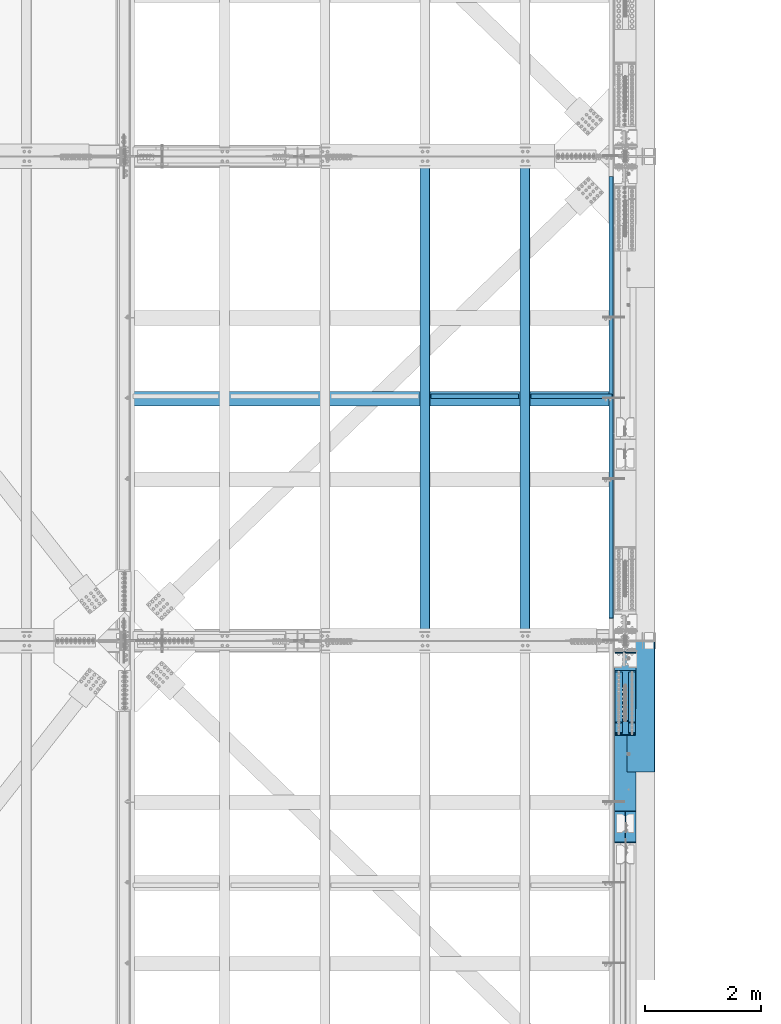
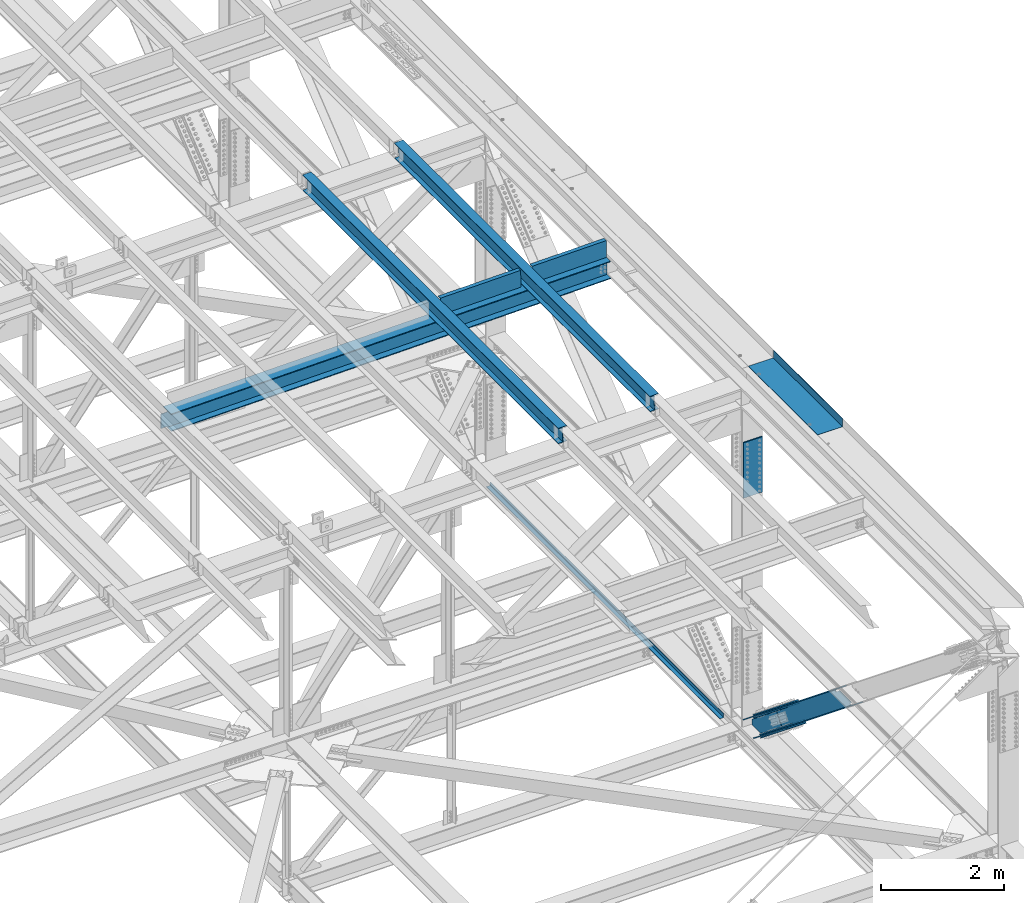
# One storey, part 1973 of 3843: 8 beams, 8 members, 10 elements without a shape of their own.
"""IFC2X3 building model written with IfcOpenShell, lengths in millimetres."""

from ifc_helpers import new_model, si_unit, frame, origin_with_axes, place, context, subcontext, project, spatial, faceted_brep, material, type_object, element, aggregate, save


model = new_model("IFC2X3")

# Units and contexts
model_context = context("Model", 3, precision=1e-05, world=origin_with_axes())
body_context = subcontext(model_context, "Body", "Model", "MODEL_VIEW")
ifc_project = project(units=[si_unit("LENGTHUNIT", "METRE", prefix="MILLI"), si_unit("AREAUNIT", "SQUARE_METRE"), si_unit("VOLUMEUNIT", "CUBIC_METRE"), si_unit("MASSUNIT", "GRAM", prefix="KILO"), si_unit("TIMEUNIT", "SECOND"), si_unit("PLANEANGLEUNIT", "RADIAN"), si_unit("SOLIDANGLEUNIT", "STERADIAN"), si_unit("THERMODYNAMICTEMPERATUREUNIT", "DEGREE_CELSIUS"), si_unit("LUMINOUSINTENSITYUNIT", "LUMEN")], contexts=[model_context])

# Site, building, storey
site_placement = place(None, origin_with_axes())
site = spatial("IfcSite", under=ifc_project, at=site_placement, CompositionType="ELEMENT")
building_placement = place(site_placement, origin_with_axes())
building = spatial("IfcBuilding", under=site, at=building_placement, Name="Undefined", CompositionType="ELEMENT")
storey_placement = place(building_placement, origin_with_axes())
storey = spatial("IfcBuildingStorey", under=building, at=storey_placement, Name="Undefined", CompositionType="ELEMENT", Elevation=0.0)

# Assembly, beam
assembly_1_placement = place(storey_placement, origin_with_axes())
assembly_1 = element("IfcElementAssembly", 1, at=assembly_1_placement, inside=storey, Name="BEAM", AssemblyPlace="NOTDEFINED", PredefinedType="RIGID_FRAME")
ifc_material_1 = material(Name="STEEL/A992")
beam_type_1 = type_object("IfcBeamType", Name="W12X26", PredefinedType="NOTDEFINED")
beam_1_placement = place(assembly_1_placement, frame((83918.3092623626, 58915.406111155, 46656.8675394248), z_axis=(-0.0211520979144407, 0.000682057999787503, 0.999776036695571), x_axis=(2.20000002012489e-08, 0.999999767294731, -0.000682210000201021)))
beam_1 = element("IfcBeam", 2, at=beam_1_placement, type_object=beam_type_1, material=ifc_material_1, Name="BEAM", ObjectType="W12X26", context=body_context, shape_type="Brep", body=[
    faceted_brep([(12.7011867508554, 82.5499999994354, -155.575000000346), (12.6947305393551, 82.5499999994572, -146.050000000338), (8343.89663442646, 82.5499999789899, -146.04999997226), (8343.90313102881, 82.5499999789899, -155.57499997229), (12.6935922641132, 3.17499999960273, -146.050000000061), (8343.89549077737, 3.17499997853884, -146.049999971998), (12.494322952225, 3.17500000000291, 146.050000000454), (8343.69626163873, 3.17499997861159, 146.050000028845), (12.4954666013145, 82.5500000004395, 146.050000000192), (8343.69740528782, 82.549999979019, 146.050000028568), (12.4889699989726, 82.5500000004395, 155.575000000223), (8343.69090868549, 82.5499999790482, 155.575000028592), (12.4865912088571, -82.550000000454, 155.575000000761), (8343.68852989539, -82.5500000218599, 155.575000029152), (12.4930878112064, -82.550000000454, 146.050000000738), (8343.69502649771, -82.5500000218599, 146.050000029121), (12.4942314602959, -3.17500000003201, 146.050000000476), (8343.69617014681, -3.17500002142333, 146.050000028852), (12.6935012020986, -3.17500000037398, -146.050000000032), (8343.89539928547, -3.17500002148154, -146.049999971976), (12.6923629268567, -82.5500000002285, -146.049999999756), (8343.89425563636, -82.5500000219035, -146.049999971714), (12.6988191383571, -82.5500000002576, -155.574999999757), (8343.90080034929, -82.5500000008251, -155.574999980301)], [[[0, 1, 2, 3]], [[1, 4, 5, 2]], [[4, 6, 7, 5]], [[6, 8, 9, 7]], [[8, 10, 11, 9]], [[10, 12, 13, 11]], [[12, 14, 15, 13]], [[14, 16, 17, 15]], [[16, 18, 19, 17]], [[18, 20, 21, 19]], [[20, 22, 23, 21]], [[22, 0, 3, 23]], [[5, 7, 9, 11, 13, 15, 17, 19, 21, 23, 3, 2]], [[22, 20, 18, 16, 14, 12, 10, 8, 6, 4, 1, 0]]]),
])
aggregate(assembly_1, [beam_1])

assembly_2_placement = place(storey_placement, origin_with_axes())
assembly_2 = element("IfcElementAssembly", 3, at=assembly_2_placement, inside=storey, Name="BEAM", AssemblyPlace="NOTDEFINED", PredefinedType="RIGID_FRAME")
beam_2_placement = place(assembly_2_placement, frame((82191.1092623841, 58915.4022524787, 46624.8375728666), z_axis=(-0.0211520975635648, 0.000657255000209259, 0.999776053316205), x_axis=(2.2000000567079e-08, 0.999999783911282, -0.000657401999942057)))
beam_2 = element("IfcBeam", 4, at=beam_2_placement, type_object=beam_type_1, material=ifc_material_1, Name="BEAM", ObjectType="W12X26", context=body_context, shape_type="Brep", body=[
    faceted_brep([(12.7011052740709, 82.550000000163, -155.575000000317), (12.6948884911471, 82.5500000001775, -146.050000000469), (8343.89668877075, 82.5499999795284, -146.050000008028), (8343.90294912967, 82.5499999795138, -155.575000008044), (12.6937864933498, 3.17499999972642, -146.050000000207), (8343.89558677295, 3.17499997907726, -146.050000007774), (12.5018021534488, 3.17500000023574, 146.050000000178), (8343.70360243306, 3.17499997960113, 146.049999992611), (12.5029041512462, 82.5500000007014, 146.049999999923), (8343.70470443086, 82.5499999800377, 146.049999992349), (12.4966437923358, 82.5500000007014, 155.574999999924), (8343.69844407195, 82.5499999800668, 155.574999992372), (12.4943516369167, -82.5500000002212, 155.575000000463), (8343.69615191653, -82.5500000208704, 155.574999992903), (12.5006119958271, -82.5500000002503, 146.050000000447), (8343.70241227544, -82.5500000208849, 146.049999992894), (12.5017139936244, -3.17499999979918, 146.050000000199), (8343.70351427323, -3.1750000204338, 146.049999992632), (12.6936983335254, -3.17500000032305, -146.050000000192), (8343.89549861313, -3.17500002095767, -146.050000007752), (12.692596335728, -82.5500000007742, -146.049999999937), (8343.89439661533, -82.5500000213942, -146.050000007497), (12.698899760122, -82.5500000007742, -155.575000000317), (8343.90065697425, -82.5500000214379, -155.575000007513)], [[[0, 1, 2, 3]], [[1, 4, 5, 2]], [[4, 6, 7, 5]], [[6, 8, 9, 7]], [[8, 10, 11, 9]], [[10, 12, 13, 11]], [[12, 14, 15, 13]], [[14, 16, 17, 15]], [[16, 18, 19, 17]], [[18, 20, 21, 19]], [[20, 22, 23, 21]], [[22, 0, 3, 23]], [[5, 7, 9, 11, 13, 15, 17, 19, 21, 23, 3, 2]], [[22, 20, 18, 16, 14, 12, 10, 8, 6, 4, 1, 0]]]),
])
aggregate(assembly_2, [beam_2])

assembly_3_placement = place(storey_placement, origin_with_axes())
assembly_3 = element("IfcElementAssembly", 5, at=assembly_3_placement, inside=storey, Name="BENT_PLATE", AssemblyPlace="NOTDEFINED", PredefinedType="RIGID_FRAME")
ifc_material_2 = material(Name="STEEL/A36")
beam_type_2 = type_object("IfcBeamType", PredefinedType="NOTDEFINED")
beam_3_placement = place(assembly_3_placement, frame((83056.8285120359, 63098.3625000037, 46453.8987739835), z_axis=(-0.999843583960508, 0.0, -0.0176863679992966), x_axis=(-0.0176863679992983, 0.0, 0.999843583960508)))
beam_3 = element("IfcBeam", 6, at=beam_3_placement, type_object=beam_type_2, material=ifc_material_2, Name="BENT_PLATE", context=body_context, shape_type="Brep", body=[
    faceted_brep([(2.38651409745216e-09, -4.76249999999709, -755.649999997448), (-2.37923813983798e-09, -4.76249999999709, 755.649999997433), (-2.37923813983798e-09, 4.76249999999709, 755.649999997433), (2.38651409745216e-09, 4.76249999999709, -755.649999997448), (327.024999945941, 4.76250000002619, 755.650000004171), (327.024999981295, 4.76250000002619, -755.650000004418), (336.549999981282, -4.76249999996799, -755.650000004447), (336.549999945928, -4.76249999996799, 755.650000004156), (327.024999958514, 71.4375000207219, 755.650000005364), (327.024999968708, 71.4375000458094, -755.650000003239), (336.549999958501, 71.4375000207219, 755.650000005349), (336.549999968687, 71.4375000458094, -755.650000003254)], [[[0, 1, 2, 3]], [[3, 2, 4, 5]], [[1, 0, 6, 7]], [[5, 4, 8, 9]], [[4, 2, 1, 7, 10, 8]], [[7, 6, 11, 10]], [[6, 0, 3, 5, 9, 11]], [[10, 11, 9, 8]]]),
])
aggregate(assembly_3, [beam_3])

assembly_4_placement = place(storey_placement, origin_with_axes())
assembly_4 = element("IfcElementAssembly", 7, at=assembly_4_placement, inside=storey, Name="BENT_PLATE", AssemblyPlace="NOTDEFINED", PredefinedType="RIGID_FRAME")
beam_4_placement = place(assembly_4_placement, frame((84728.2762852714, 63098.3625000033, 46483.296312261), z_axis=(-0.999843562078246, 0.0, -0.0176876050013672), x_axis=(-0.0176876050013679, 0.0, 0.999843562078246)))
beam_4 = element("IfcBeam", 8, at=beam_4_placement, type_object=beam_type_2, material=ifc_material_2, Name="BENT_PLATE", context=body_context, shape_type="Brep", body=[
    faceted_brep([(2.20461515709758e-09, -4.76249999999709, -698.499999997657), (-2.19733919948339e-09, -4.76249999999709, 698.499999997628), (-2.19733919948339e-09, 4.76249999999709, 698.499999997628), (2.20461515709758e-09, 4.76249999999709, -698.499999997657), (327.025000023619, 4.76250000002619, 698.499999999302), (327.025000025125, 4.76250000002619, -698.50000000326), (336.550000025134, -4.76249999996799, -698.500000003318), (336.550000023642, -4.76249999996799, 698.499999999243), (327.025000023437, 71.4374999717184, 698.499999999287), (327.025000025285, 71.4374999714419, -698.500000003274), (336.550000023461, 71.4374999717184, 698.499999999229), (336.550000025301, 71.4374999714419, -698.500000003332)], [[[0, 1, 2, 3]], [[3, 2, 4, 5]], [[1, 0, 6, 7]], [[5, 4, 8, 9]], [[4, 2, 1, 7, 10, 8]], [[7, 6, 11, 10]], [[6, 0, 3, 5, 9, 11]], [[10, 11, 9, 8]]]),
])
aggregate(assembly_4, [beam_4])

# Assembly, members
assembly_5_placement = place(storey_placement, origin_with_axes())
assembly_5 = element("IfcElementAssembly", 9, at=assembly_5_placement, inside=storey, Name="BEAM", AssemblyPlace="NOTDEFINED", PredefinedType="RIGID_FRAME")
ifc_material_3 = material(Name="STEEL/A572-50")
member_type_1 = type_object("IfcMemberType", PredefinedType="NOTDEFINED")
member_1_placement = place(assembly_5_placement, frame((85534.5, 58180.9418753998, 39957.4534431505), z_axis=(1.0, 0.0, 0.0), x_axis=(0.0, -0.777176657156862, 0.629282483127002)))
member_1 = element("IfcMember", 10, at=member_1_placement, type_object=member_type_1, material=ifc_material_3, Name="PLATE", context=body_context, shape_type="Brep", body=[
    faceted_brep([(-4.36557456851006e-11, 12.7000000000116, -63.5), (-4.36557456851006e-11, 12.7000000000116, 63.5), (1104.90000001677, 12.7000000017251, 63.5), (1104.90000001677, 12.7000000017251, -63.5), (1.45519152283669e-11, -12.700000000008, 63.5), (1104.90000001682, -12.6999999982909, 63.5), (1.45519152283669e-11, -12.700000000008, -63.5), (1104.90000001682, -12.6999999982909, -63.5)], [[[0, 1, 2, 3]], [[1, 4, 5, 2]], [[4, 6, 7, 5]], [[6, 0, 3, 7]], [[5, 7, 3, 2]], [[6, 4, 1, 0]]]),
])
member_2_placement = place(assembly_5_placement, frame((85534.5, 58366.6356795802, 40186.7890649789), z_axis=(1.0, 0.0, 0.0), x_axis=(0.0, -0.777176657156862, 0.629282483127002)))
member_2 = element("IfcMember", 11, at=member_2_placement, type_object=member_type_1, material=ifc_material_3, Name="PLATE", context=body_context, shape_type="Brep", body=[
    faceted_brep([(-4.36557456851006e-11, 12.7000000000116, -63.5), (-4.36557456851006e-11, 12.7000000000116, 63.5), (1104.90000001677, 12.7000000017251, 63.5), (1104.90000001677, 12.7000000017251, -63.5), (1.45519152283669e-11, -12.700000000008, 63.5), (1104.90000001682, -12.6999999982909, 63.5), (1.45519152283669e-11, -12.700000000008, -63.5), (1104.90000001682, -12.6999999982909, -63.5)], [[[0, 1, 2, 3]], [[1, 4, 5, 2]], [[4, 6, 7, 5]], [[6, 0, 3, 7]], [[5, 7, 3, 2]], [[6, 4, 1, 0]]]),
])
member_3_placement = place(assembly_5_placement, frame((85763.1, 58180.9418753998, 39957.4534431505), z_axis=(1.0, 0.0, 0.0), x_axis=(0.0, -0.777176657156862, 0.629282483127002)))
member_3 = element("IfcMember", 12, at=member_3_placement, type_object=member_type_1, material=ifc_material_3, Name="PLATE", context=body_context, shape_type="Brep", body=[
    faceted_brep([(-4.36557456851006e-11, 12.7000000000116, -63.5), (-4.36557456851006e-11, 12.7000000000116, 63.5), (1104.90000001677, 12.7000000017251, 63.5), (1104.90000001677, 12.7000000017251, -63.5), (1.45519152283669e-11, -12.700000000008, 63.5), (1104.90000001682, -12.6999999982909, 63.5), (1.45519152283669e-11, -12.700000000008, -63.5), (1104.90000001682, -12.6999999982909, -63.5)], [[[0, 1, 2, 3]], [[1, 4, 5, 2]], [[4, 6, 7, 5]], [[6, 0, 3, 7]], [[5, 7, 3, 2]], [[6, 4, 1, 0]]]),
])
member_4_placement = place(assembly_5_placement, frame((85763.1, 58366.6356795802, 40186.7890649789), z_axis=(1.0, 0.0, 0.0), x_axis=(0.0, -0.777176657156862, 0.629282483127002)))
member_4 = element("IfcMember", 13, at=member_4_placement, type_object=member_type_1, material=ifc_material_3, Name="PLATE", context=body_context, shape_type="Brep", body=[
    faceted_brep([(-4.36557456851006e-11, 12.7000000000116, -63.5), (-4.36557456851006e-11, 12.7000000000116, 63.5), (1104.90000001677, 12.7000000017251, 63.5), (1104.90000001677, 12.7000000017251, -63.5), (1.45519152283669e-11, -12.700000000008, 63.5), (1104.90000001682, -12.6999999982909, 63.5), (1.45519152283669e-11, -12.700000000008, -63.5), (1104.90000001682, -12.6999999982909, -63.5)], [[[0, 1, 2, 3]], [[1, 4, 5, 2]], [[4, 6, 7, 5]], [[6, 0, 3, 7]], [[5, 7, 3, 2]], [[6, 4, 1, 0]]]),
])
member_type_2 = type_object("IfcMemberType", PredefinedType="NOTDEFINED")
member_5_placement = place(assembly_5_placement, frame((85648.8, 57536.1161798013, 40916.8898443647), z_axis=(1.0, 0.0, 0.0), x_axis=(0.0, 0.777176657156857, -0.629282483127008)))
member_5 = element("IfcMember", 14, at=member_5_placement, type_object=member_type_2, material=ifc_material_3, Name="PLATE", context=body_context, shape_type="Brep", body=[
    faceted_brep([(-1.45519152283669e-11, 12.7000000000025, -177.800000000003), (-1.45519152283669e-11, 12.7000000000025, 177.800000000003), (1104.90000001682, 12.7000000017051, 177.800000000003), (1104.90000001682, 12.7000000017051, -177.800000000003), (4.36557456851006e-11, -12.7000000000171, 177.800000000003), (1104.90000001686, -12.6999999983072, 177.800000000003), (4.36557456851006e-11, -12.7000000000171, -177.800000000003), (1104.90000001686, -12.6999999983072, -177.800000000003)], [[[0, 1, 2, 3]], [[1, 4, 5, 2]], [[4, 6, 7, 5]], [[6, 0, 3, 7]], [[5, 7, 3, 2]], [[6, 4, 1, 0]]]),
])
member_6_placement = place(assembly_5_placement, frame((85648.8, 57294.1502001233, 40618.0569422348), z_axis=(1.0, 0.0, 0.0), x_axis=(0.0, 0.777176657156857, -0.629282483127008)))
member_6 = element("IfcMember", 15, at=member_6_placement, type_object=member_type_2, material=ifc_material_3, Name="PLATE", context=body_context, shape_type="Brep", body=[
    faceted_brep([(-1.45519152283669e-11, 12.7000000000025, -177.800000000003), (-1.45519152283669e-11, 12.7000000000025, 177.800000000003), (1104.90000001682, 12.7000000017051, 177.800000000003), (1104.90000001682, 12.7000000017051, -177.800000000003), (4.36557456851006e-11, -12.7000000000171, 177.800000000003), (1104.90000001686, -12.6999999983072, 177.800000000003), (4.36557456851006e-11, -12.7000000000171, -177.800000000003), (1104.90000001686, -12.6999999983072, -177.800000000003)], [[[0, 1, 2, 3]], [[1, 4, 5, 2]], [[4, 6, 7, 5]], [[6, 0, 3, 7]], [[5, 7, 3, 2]], [[6, 4, 1, 0]]]),
])

# Assembly, member
assembly_6_placement = place(storey_placement, origin_with_axes())
assembly_6 = element("IfcElementAssembly", 16, at=assembly_6_placement, inside=storey, Name="V. BRACE", AssemblyPlace="NOTDEFINED", PredefinedType="RIGID_FRAME")
member_type_3 = type_object("IfcMemberType", Name="W14X99", PredefinedType="NOTDEFINED")
member_7_placement = place(assembly_6_placement, frame((85648.8, 57844.3787430634, 40419.6957547924), z_axis=(0.0, 0.629282483127005, 0.777176657156859), x_axis=(0.0, -0.777176657156862, 0.629282483127002)))
member_7 = element("IfcMember", 17, at=member_7_placement, type_object=member_type_3, material=ifc_material_1, Name="V. BRACE", ObjectType="W14X99", context=body_context, shape_type="Brep", body=[
    faceted_brep([(2542.53048689721, -185.737500000003, 179.535611566287), (2542.52458249779, -185.737500000003, 160.337499991481), (2542.52458249779, -6.35000000000582, 160.337499991481), (2542.52458249779, 6.35000000000582, 160.337499991481), (2542.52458249779, 185.737500000003, 160.337499991481), (2542.71282133633, 185.737500000003, 179.387499991441), (6.35000000674336, -185.737500000003, -179.387500001117), (6.35000000674336, 185.737500000003, -179.387500001117), (2960.83752571871, 185.737500000003, -179.387500009427), (2960.83752571871, -185.737500000003, -179.387500009427), (2888.33822765505, -185.737500000003, -160.275293699931), (6.35000000674336, -185.737500000003, -160.33750000099), (2960.84078869066, -185.737500000003, -160.273728767774), (2888.33822811467, -6.35000000000582, -160.337500009206), (6.35000000674336, -6.35000000000582, -160.33750000099), (2960.93512241314, -6.35000000000582, -160.337500009453), (2893.8406720211, -6.35000000000582, -122.198223219486), (2913.99071803143, 6.35000000000582, -122.204220799918), (2612.90412650049, 6.35000000000582, 122.370595140703), (2592.75489625221, -6.35000000000582, 122.375929923117), (2888.33822811467, 185.737500000003, -160.337500009206), (6.35000000674336, 185.737500000003, -160.33750000099), (6.35000000674336, 6.35000000000582, -160.33750000099), (2888.33822811467, 6.35000000000582, -160.337500009206), (2960.93512241314, 6.35000000000582, -160.337500009453), (2960.93512241314, 185.737500000003, -160.337500009453), (2868.15054113571, 6.35000000000582, -122.190576655019), (2862.65099777642, 6.35000000000582, -123.936641747176), (2859.16858996917, 6.35000000000582, -128.537354336615), (2858.98126230098, 6.35000000000582, -134.304383798255), (2862.1577586964, 6.35000000000582, -139.121394397851), (6.35000000639411, 6.35000000000582, 160.337500001014), (2491.72499524875, 6.35000000000582, 160.337499991641), (2474.22024967483, 6.35000000000582, 137.736147825781), (2472.29288533372, 6.35000000000582, 132.871501461894), (2473.22594364031, 6.35000000000582, 127.722820102004), (2476.73784275566, 6.35000000000582, 123.843892137651), (2481.76874857933, 6.35000000000582, 122.405315013355), (2474.22024967483, -6.35000000000582, 137.736147825781), (2491.72499524875, -6.35000000000582, 160.337499991641), (2472.29288533372, -6.35000000000582, 132.871501461894), (2473.22594364031, -6.35000000000582, 127.722820102004), (2476.73784275566, -6.35000000000582, 123.843892137651), (2481.76874857933, -6.35000000000582, 122.405315013355), (6.35000000639411, -6.35000000000582, 160.337500001014), (2862.1577586964, -6.35000000000582, -139.121394397851), (2858.98126230098, -6.35000000000582, -134.304383798255), (2859.16858996917, -6.35000000000582, -128.537354336615), (2862.65099777642, -6.35000000000582, -123.936641747176), (2868.15054113571, -6.35000000000582, -122.190576655019), (6.35000000639411, -185.737500000003, 160.337500001014), (6.35000000636501, -185.737500000003, 179.387500001133), (6.35000000636501, 185.737500000003, 179.387500001133), (6.35000000639411, 185.737500000003, 160.337500001014), (2491.72499524875, 185.737500000003, 160.337499991641), (2491.72499524875, -185.737500000003, 160.337499991641)], [[[0, 1, 2, 3, 4, 5]], [[6, 7, 8, 9]], [[10, 11, 6, 9, 12]], [[13, 14, 11, 10, 12, 15]], [[16, 17, 18, 19]], [[20, 21, 22, 23, 24, 25]], [[17, 26, 27, 28, 29, 30, 23, 22, 31, 32, 33, 34, 35, 36, 37, 18]], [[38, 33, 32, 39]], [[40, 34, 33, 38]], [[41, 35, 34, 40]], [[42, 36, 35, 41]], [[43, 37, 36, 42]], [[18, 37, 43, 19]], [[42, 41, 40, 38, 39, 44, 14, 13, 45, 46, 47, 48, 49, 16, 19, 43]], [[17, 16, 49, 26]], [[48, 27, 26, 49]], [[47, 28, 27, 48]], [[46, 29, 28, 47]], [[45, 30, 29, 46]], [[13, 23, 30, 45]], [[15, 24, 23, 13]], [[12, 9, 8, 25, 24, 15]], [[7, 21, 20, 25, 8]], [[6, 11, 14, 44, 50, 51, 52, 53, 31, 22, 21, 7]], [[52, 51, 0, 5]], [[54, 53, 52, 5, 4]], [[32, 31, 53, 54, 4, 3]], [[39, 32, 3, 2]], [[55, 50, 44, 39, 2, 1]], [[51, 50, 55, 1, 0]]]),
])
aggregate(assembly_6, [member_7])

# Member
member_8_placement = place(assembly_5_placement, frame((85648.8, 58915.3252376215, 39553.1464287516), z_axis=(0.0, 0.629019577247337, 0.777389459305682), x_axis=(0.0, -0.777389459305681, 0.629019577247339)))
member_8 = element("IfcMember", 18, at=member_8_placement, type_object=member_type_3, material=ifc_material_1, Name="BEAM", ObjectType="W14X99", context=body_context, shape_type="Brep", body=[
    faceted_brep([(366.11993890228, 6.35000000000582, 131.919701286381), (297.396498668953, 6.35000000000582, 46.9861155318076), (279.555742284108, -6.35000000000582, 45.1273226102066), (349.799318523146, -6.35000000000582, 131.939606540561), (1371.20833083491, -185.737500000003, 179.387499998361), (1371.20833083491, 185.737500000003, 179.387499998361), (388.191450808619, 185.737500000003, 179.387499999274), (388.191450808619, -185.737500000003, 179.387499997812), (1371.21477429129, 185.737500000003, 160.337499998405), (410.416450816865, 185.737500000003, 160.337499999296), (410.378828766639, 185.737500000003, 160.386303128733), (388.191450810176, 185.737500000003, 160.360327501345), (410.378828766639, -185.737500000003, 160.386303128733), (388.191450810176, -185.737500000003, 160.360327501345), (410.416450816865, -185.737500000003, 160.337499999296), (1371.21477429129, -185.737500000003, 160.337499998405), (1371.21477429129, -6.35000000000582, 160.337499998405), (410.416450816865, -6.35000000000582, 160.337499999296), (579.878535977754, 6.35000000000582, -131.625140108364), (579.878535977754, -6.35000000000582, -131.625140108364), (496.841843801813, -6.35000000000582, -131.62029823134), (516.969164940005, 6.35000000000582, -131.621471857258), (584.918308241206, 6.35000000000582, -133.068016552646), (584.918308241206, -6.35000000000582, -133.068016552646), (588.431342627009, 6.35000000000582, -136.959004384137), (588.431342627009, -6.35000000000582, -136.959004384137), (589.353525248865, 6.35000000000582, -142.11950592108), (589.353525248865, -6.35000000000582, -142.11950592108), (587.405522850691, 6.35000000000582, -146.986382081158), (587.405522850691, -6.35000000000582, -146.986382081158), (1371.32323914045, 6.35000000000582, -160.337500000946), (1371.32323914045, 185.737500000003, -160.337500000946), (577.054154873018, 185.737500000003, -160.337500000212), (577.054154873018, 6.35000000000582, -160.337500000212), (1371.32968259681, 185.737500000003, -179.387500000909), (1371.32968259681, -185.737500000003, -179.387500000909), (554.792979067643, -185.737500000003, -179.387500000153), (554.792979067643, 185.737500000003, -179.387500000153), (559.683107903373, -6.35000000000582, -160.337500000183), (554.790254198328, -6.35000000000582, -160.326015082814), (554.790244223026, -6.35000000000582, -160.337500000193), (559.683107903373, -185.737500000003, -160.337500000183), (554.790255840118, -185.737500000003, -160.337500000183), (1371.32323914045, -185.737500000003, -160.337500000946), (577.054154873018, -185.737500000003, -160.337500000212), (577.022598861658, -185.737500000003, -160.378200710446), (1371.32323914045, -6.35000000000582, -160.337500000946), (577.054154873018, -6.35000000000582, -160.337500000212), (577.022598861658, 185.737500000003, -160.378200710446), (559.683107903373, 6.35000000000582, -160.337500000183), (554.790244223026, 6.35000000000582, -160.337500000193), (554.790254198328, 6.35000000000582, -160.326015082814), (559.683107903373, 185.737500000003, -160.337500000183), (554.790244223026, 185.737500000003, -160.337500000193), (1371.21477429129, 6.35000000000582, 160.337499998405), (410.416450816865, 6.35000000000582, 160.337499999296), (420.541831244729, 6.35000000000582, 147.202908749569), (420.541831244729, -6.35000000000582, 147.202908749569), (422.475996896464, 6.35000000000582, 142.334190349343), (422.475996896464, -6.35000000000582, 142.334190349343), (421.543020108831, 6.35000000000582, 137.179098697118), (421.543020108831, -6.35000000000582, 137.179098697118), (418.02513578246, 6.35000000000582, 133.297101080502), (418.02513578246, -6.35000000000582, 133.297101080502), (412.986539454258, 6.35000000000582, 131.862540983981), (412.986539454258, -6.35000000000582, 131.862540983981)], [[[0, 1, 2, 3]], [[4, 5, 6, 7]], [[5, 8, 9, 10, 11, 6]], [[10, 12, 13, 11]], [[7, 6, 11, 13]], [[12, 14, 15, 4, 7, 13]], [[16, 15, 14, 17]], [[18, 19, 20, 21]], [[19, 18, 22, 23]], [[23, 22, 24, 25]], [[25, 24, 26, 27]], [[27, 26, 28, 29]], [[30, 31, 32, 33]], [[34, 35, 36, 37]], [[38, 39, 40]], [[41, 38, 40, 42]], [[35, 43, 44, 45, 41, 42, 36]], [[43, 46, 47, 44]], [[29, 28, 33, 32, 48, 45, 44, 47]], [[49, 50, 51]], [[38, 41, 45, 48, 52, 49, 51, 39]], [[49, 52, 53, 50]], [[36, 42, 40, 39, 51, 50, 53, 37]], [[52, 48, 32, 31, 34, 37, 53]], [[30, 54, 8, 5, 4, 15, 16, 46, 43, 35, 34, 31]], [[8, 54, 55, 9]], [[17, 14, 12, 10, 9, 55, 56, 57]], [[57, 56, 58, 59]], [[59, 58, 60, 61]], [[61, 60, 62, 63]], [[63, 62, 64, 65]], [[65, 64, 0, 3]], [[20, 19, 23, 25, 27, 29, 47, 46, 16, 17, 57, 59, 61, 63, 65, 3, 2]], [[21, 20, 2, 1]], [[64, 62, 60, 58, 56, 55, 54, 30, 33, 28, 26, 24, 22, 18, 21, 1, 0]]]),
])

aggregate(assembly_5, [member_1, member_2, member_3, member_4, member_5, member_6, member_8])

# Assembly, beam
assembly_7_placement = place(storey_placement, origin_with_axes())
assembly_7 = element("IfcElementAssembly", 19, at=assembly_7_placement, inside=storey, Name="BENT_PLATE", AssemblyPlace="NOTDEFINED", PredefinedType="RIGID_FRAME")
beam_type_3 = type_object("IfcBeamType", PredefinedType="NOTDEFINED")
beam_5_placement = place(assembly_7_placement, frame((85369.3999999992, 63112.6500000001, 39627.1749999967), z_axis=(0.0, 1.0, 0.0), x_axis=(1.0, 0.0, 0.0)))
beam_5 = element("IfcBeam", 20, at=beam_5_placement, type_object=beam_type_3, material=ifc_material_2, Name="BENT_PLATE", context=body_context, shape_type="Brep", body=[
    faceted_brep([(73.0250000000524, -7.56699591875076e-10, -3810.00000000004), (69.8500000000204, -3.17500000000291, -3806.82500000006), (0.0, -3.17500000000291, -3806.82500000006), (0.0, -7.56699591875076e-10, -3810.0), (73.0250000001397, -73.0250000000306, -3810.00000000004), (69.8500000000931, -73.0250000000015, -3806.82500000006), (0.0, 3.17500000000291, -3810.0), (0.0, 3.17500000000291, 3810.0), (76.2000000000116, 3.17500000000291, 3810.0), (76.2000000000116, 3.17500000000291, -3810.0), (0.0, -3.17500000000291, 3810.0), (69.8500000000204, -3.17500000000291, 3810.0), (69.8500000000931, -73.0250000000015, 3810.0), (76.200000000099, -73.0249999999869, 3810.0), (76.200000000099, -73.0249999999869, -3810.0)], [[[0, 1, 2, 3]], [[4, 5, 1, 0]], [[6, 7, 8, 9]], [[8, 7, 10, 11, 12, 13]], [[9, 8, 13, 14]], [[3, 6, 9, 14, 4, 0]], [[10, 7, 6, 3, 2]], [[11, 10, 2, 1]], [[12, 11, 1, 5]], [[14, 13, 12, 5, 4]]]),
])
aggregate(assembly_7, [beam_5])

assembly_8_placement = place(storey_placement, origin_with_axes())
assembly_8 = element("IfcElementAssembly", 21, at=assembly_8_placement, inside=storey, Name="BEAM", AssemblyPlace="NOTDEFINED", PredefinedType="RIGID_FRAME")
beam_type_4 = type_object("IfcBeamType", PredefinedType="NOTDEFINED")
beam_6_placement = place(assembly_8_placement, frame((85648.8, 58716.8625120956, 45450.1298074406), z_axis=(1.0, 0.0, 0.0), x_axis=(0.0, 0.0, -1.0)))
beam_6 = element("IfcBeam", 22, at=beam_6_placement, type_object=beam_type_4, material=ifc_material_3, Name="PLATE", context=body_context, shape_type="Brep", body=[
    faceted_brep([(-1.45519152283669e-11, 12.7000000000025, -177.800000000003), (-1.45519152283669e-11, 12.7000000000025, 177.800000000003), (1104.90000001682, 12.7000000017051, 177.800000000003), (1104.90000001682, 12.7000000017051, -177.800000000003), (4.36557456851006e-11, -12.7000000000171, 177.800000000003), (1104.90000001686, -12.6999999983072, 177.800000000003), (4.36557456851006e-11, -12.7000000000171, -177.800000000003), (1104.90000001686, -12.6999999983072, -177.800000000003)], [[[0, 1, 2, 3]], [[1, 4, 5, 2]], [[4, 6, 7, 5]], [[6, 0, 3, 7]], [[5, 7, 3, 2]], [[6, 4, 1, 0]]]),
])
aggregate(assembly_8, [beam_6])

assembly_9_placement = place(storey_placement, origin_with_axes())
assembly_9 = element("IfcElementAssembly", 23, at=assembly_9_placement, inside=storey, Name="BEAM", AssemblyPlace="NOTDEFINED", PredefinedType="RIGID_FRAME")
beam_type_5 = type_object("IfcBeamType", PredefinedType="NOTDEFINED")
beam_7_placement = place(assembly_9_placement, frame((85680.5500000015, 57785.0, 46772.5124999999), z_axis=(0.0, -1.0, 0.0), x_axis=(1.0, 0.0, 0.0)))
beam_7 = element("IfcBeam", 24, at=beam_7_placement, type_object=beam_type_5, material=ifc_material_2, Name="BENT_PLATE", context=body_context, shape_type="Brep", body=[
    faceted_brep([(466.724999999991, 4.76249999999709, -1127.12500004766), (469.899998426787, 1.58750004768081, -1130.3), (0.0, 1.58750004768081, -1130.3), (0.0, 4.76249999999709, -1127.12500004766), (466.725000000006, 160.337499999994, -1127.12500004766), (469.899998426801, 160.337499999994, -1130.3), (0.0, 4.76249999999709, 1130.3), (466.724999999991, 4.76249999999709, 1130.3), (0.0, -4.76249999999709, -1130.3), (0.0, -4.76249999999709, 1130.3), (476.249999999985, -4.76249999999709, -1130.3), (476.249999999985, -4.76249999999709, 1130.3), (466.725000000006, 160.337499999994, 1130.3), (476.25, 160.337499999994, 1130.3), (476.25, 160.337499999994, -1130.3)], [[[0, 1, 2, 3]], [[4, 5, 1, 0]], [[6, 7, 0, 3]], [[8, 9, 6, 3, 2]], [[9, 8, 10, 11]], [[7, 12, 4, 0]], [[7, 6, 9, 11, 13, 12]], [[11, 10, 14, 13]], [[5, 14, 10, 8, 2, 1]], [[12, 13, 14, 5, 4]]]),
])
aggregate(assembly_9, [beam_7])

assembly_10_placement = place(storey_placement, origin_with_axes())
assembly_10 = element("IfcElementAssembly", 25, at=assembly_10_placement, inside=storey, Name="BEAM", AssemblyPlace="NOTDEFINED", PredefinedType="RIGID_FRAME")
beam_type_6 = type_object("IfcBeamType", Name="W14X61", PredefinedType="NOTDEFINED")
beam_8_placement = place(assembly_10_placement, frame((77012.799999465, 63093.6, 46170.5665925295), z_axis=(-0.0176876050013679, 0.0, 0.999843562078246), x_axis=(0.999843562078246, 0.0, 0.017687605001384)))
beam_8 = element("IfcBeam", 26, at=beam_8_placement, type_object=beam_type_6, material=ifc_material_1, Name="BEAM", ObjectType="W14X61", context=body_context, shape_type="Brep", body=[
    faceted_brep([(15.7035115216859, -4.76249999999709, -144.462499973823), (15.7035115216859, 4.76249999999709, -144.462499973823), (129.441842387037, 4.76249999999709, -144.46249997017), (129.441842387037, -4.76249999999709, -144.46249997017), (134.301921905149, 4.76249999999709, -145.429229892696), (134.301921905149, -4.76249999999709, -145.429229892696), (138.422098373339, 4.76249999999709, -148.18224379317), (138.422098373339, -4.76249999999709, -148.18224379317), (141.175112273791, 4.76249999999709, -152.302420261367), (141.175112273791, -4.76249999999709, -152.302420261367), (142.141842196303, -4.76249999999709, -157.162499779472), (142.141842196303, 4.76249999999709, -157.162499779472), (142.141842196288, 4.76249999999709, -160.337500000089), (142.141842196288, 127.0, -160.337500000089), (142.141842196201, 127.0, -176.212500000118), (142.141842196201, -127.0, -176.212500000118), (142.141842196288, -127.0, -160.337500000089), (142.141842196288, -4.76249999999709, -160.337500000089), (8418.30016485162, -127.0, 160.337500011257), (8418.30016485172, -127.0, 176.212500011286), (142.141842201207, -127.0, 176.212500000489), (142.141842201119, -127.0, 160.337500000467), (8418.30016485172, 127.0, 176.212500011286), (142.141842201207, 127.0, 176.212500000489), (8418.30016485162, 127.0, 160.337500011257), (142.141842201119, 127.0, 160.337500000467), (8418.30016485162, 4.76249999999709, 160.337500011257), (142.141842201119, 4.76249999999709, 160.337500000467), (129.441842391243, -4.76249999999709, 144.46250003131), (129.441842391243, 4.76249999999709, 144.46250003131), (20.8147023829661, 4.76249999999709, 144.462500031172), (20.8147023829661, -4.76249999999709, 144.462500031172), (134.301921909282, -4.76249999999709, 145.429229953967), (134.301921909282, 4.76249999999709, 145.429229953967), (138.422098377443, -4.76249999999709, 148.18224385447), (138.422098377443, 4.76249999999709, 148.18224385447), (141.175112277982, -4.76249999999709, 152.30242032263), (141.175112277982, 4.76249999999709, 152.30242032263), (142.141842200668, -4.76249999999709, 157.162499840662), (142.141842200668, 4.76249999999709, 157.162499840662), (142.141842201119, -4.76249999999709, 160.337500000467), (8418.30016485162, -4.76249999999709, 160.337500011257), (8418.30016484929, 4.76249999999709, -160.337499989291), (8418.30016484929, -4.76249999999709, -160.337499989291), (8418.30016484929, -127.0, -160.337499989291), (8418.30016484918, -127.0, -176.21249998932), (8418.30016484918, 127.0, -176.21249998932), (8418.30016484929, 127.0, -160.337499989291), (16.633435948359, 4.76249999999709, -91.8958042130544), (20.7121976633498, 4.76249999999709, 138.668121203002)], [[[0, 1, 2, 3]], [[3, 2, 4, 5]], [[5, 4, 6, 7]], [[7, 6, 8, 9]], [[10, 11, 12, 13, 14, 15, 16, 17]], [[9, 8, 11, 10]], [[18, 19, 20, 21]], [[19, 22, 23, 20]], [[22, 24, 25, 23]], [[24, 26, 27, 25]], [[28, 29, 30, 31]], [[32, 33, 29, 28]], [[34, 35, 33, 32]], [[36, 37, 35, 34]], [[38, 39, 37, 36]], [[20, 23, 25, 27, 39, 38, 40, 21]], [[41, 18, 21, 40]], [[42, 26, 24, 22, 19, 18, 41, 43, 44, 45, 46, 47]], [[44, 43, 17, 16]], [[45, 44, 16, 15]], [[46, 45, 15, 14]], [[47, 46, 14, 13]], [[42, 47, 13, 12]], [[6, 4, 2, 1, 48, 49, 30, 29, 33, 35, 37, 39, 27, 26, 42, 12, 11, 8]], [[31, 30, 49, 48, 1, 0]], [[43, 41, 40, 38, 36, 34, 32, 28, 31, 0, 3, 5, 7, 9, 10, 17]]]),
])
aggregate(assembly_10, [beam_8])

save(model, "model.ifc")
